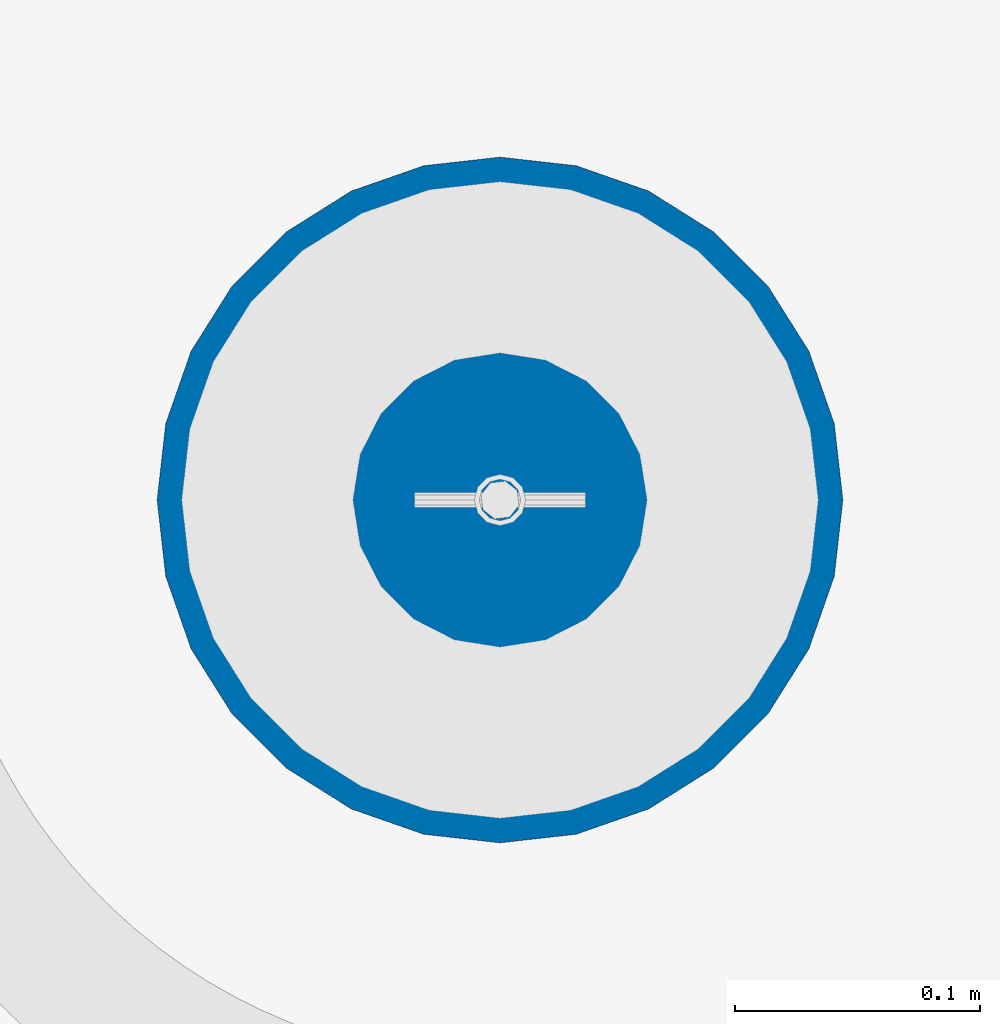
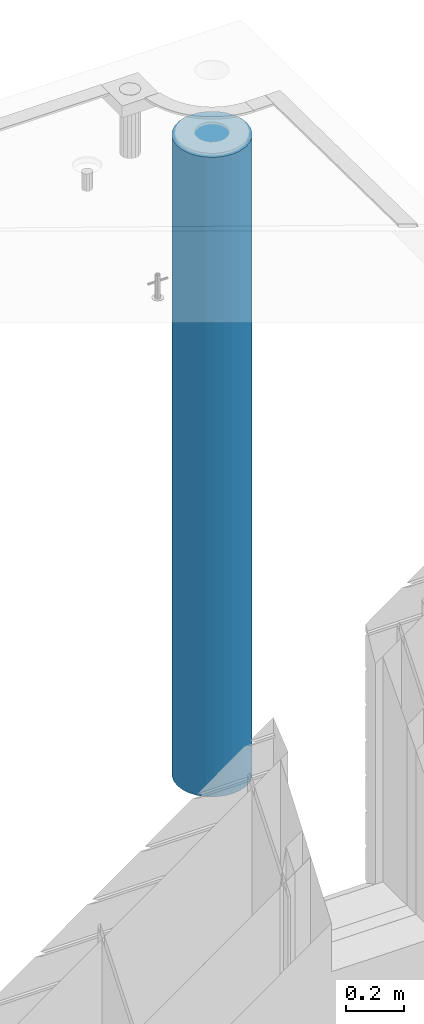
# One storey, part 7 of 341: 1 column, 1 element without a shape of its own.
"""IFC2X3 building model written with IfcOpenShell, lengths in millimetres."""

from ifc_helpers import new_model, si_unit, frame, origin_with_axes, place, context, subcontext, project, spatial, faceted_brep, material, type_object, element, aggregate, save


model = new_model("IFC2X3")

# Units and contexts
model_context = context("Model", 3, precision=1e-05, world=origin_with_axes())
body_context = subcontext(model_context, "Body", "Model", "MODEL_VIEW")
ifc_project = project(units=[si_unit("LENGTHUNIT", "METRE", prefix="MILLI"), si_unit("AREAUNIT", "SQUARE_METRE"), si_unit("VOLUMEUNIT", "CUBIC_METRE"), si_unit("MASSUNIT", "GRAM", prefix="KILO"), si_unit("TIMEUNIT", "SECOND"), si_unit("PLANEANGLEUNIT", "RADIAN"), si_unit("SOLIDANGLEUNIT", "STERADIAN"), si_unit("THERMODYNAMICTEMPERATUREUNIT", "DEGREE_CELSIUS"), si_unit("LUMINOUSINTENSITYUNIT", "LUMEN")], contexts=[model_context])

# Site, building, storey
site_placement = place(None, origin_with_axes())
site = spatial("IfcSite", under=ifc_project, at=site_placement, CompositionType="ELEMENT")
building_placement = place(site_placement, origin_with_axes())
building = spatial("IfcBuilding", under=site, at=building_placement, CompositionType="ELEMENT")
storey_placement = place(building_placement, origin_with_axes())
storey = spatial("IfcBuildingStorey", under=building, at=storey_placement, Name="5", CompositionType="ELEMENT", Elevation=0.0)

# Assembly, column
assembly_placement = place(storey_placement, origin_with_axes())
assembly = element("IfcElementAssembly", 1, at=assembly_placement, inside=storey, AssemblyPlace="NOTDEFINED", PredefinedType="REINFORCEMENT_UNIT")
ifc_material = material(Name="CONCRETE/C30/37")
column_type = type_object("IfcColumnType", Name="D280", PredefinedType="NOTDEFINED")
column_placement = place(assembly_placement, frame((35009.9987952044, 22669.984888838, 93725.0), z_axis=(-1.0, 3.00000001838171e-08, 0.0), x_axis=(0.0, 0.0, 1.0)))
column = element("IfcColumn", 2, at=column_placement, type_object=column_type, material=ifc_material, ObjectType="D280", context=body_context, shape_type="Brep", body=[
    faceted_brep([(0.0, -140.0, 0.0), (0.0, -136.489907705454, -31.1529307538876), (2710.0, -136.489907705454, -31.1529307538876), (2710.0, -140.0, 0.0), (0.0, -126.135641506338, -60.7437234764584), (2710.0, -126.135641506338, -60.7437234764584), (0.0, -109.456407545524, -87.2885722602223), (2710.0, -109.456407545524, -87.2885722602223), (0.0, -87.2885722602223, -109.456407545527), (2710.0, -87.2885722602223, -109.456407545527), (0.0, -60.7437234764584, -126.135641506342), (2710.0, -60.7437234764584, -126.135641506342), (0.0, -31.152930753884, -136.489907705458), (2710.0, -31.152930753884, -136.489907705458), (0.0, 0.0, -140.0), (2710.0, 0.0, -140.0), (0.0, 31.152930753884, -136.489907705458), (2710.0, 31.152930753884, -136.489907705458), (0.0, 60.7437234764584, -126.135641506342), (2710.0, 60.7437234764584, -126.135641506342), (0.0, 87.2885722602223, -109.456407545527), (2710.0, 87.2885722602223, -109.456407545527), (0.0, 109.456407545524, -87.2885722602223), (2710.0, 109.456407545524, -87.2885722602223), (0.0, 126.135641506338, -60.7437234764584), (2710.0, 126.135641506338, -60.7437234764584), (0.0, 136.489907705454, -31.1529307538876), (2710.0, 136.489907705454, -31.1529307538876), (0.0, 140.0, 0.0), (2710.0, 140.0, 0.0), (0.0, 136.489907705454, 31.1529307538876), (2710.0, 136.489907705454, 31.1529307538876), (0.0, 126.135641506338, 60.7437234764584), (2710.0, 126.135641506338, 60.7437234764584), (0.0, 109.456407545524, 87.2885722602223), (2710.0, 109.456407545524, 87.2885722602223), (0.0, 87.2885722602223, 109.456407545527), (2710.0, 87.2885722602223, 109.456407545527), (0.0, 60.7437234764584, 126.135641506342), (2710.0, 60.7437234764584, 126.135641506342), (0.0, 31.152930753884, 136.489907705458), (2710.0, 31.152930753884, 136.489907705458), (0.0, 0.0, 140.0), (2710.0, 0.0, 140.0), (0.0, -31.152930753884, 136.489907705458), (2710.0, -31.152930753884, 136.489907705458), (0.0, -60.7437234764584, 126.135641506342), (2710.0, -60.7437234764584, 126.135641506342), (0.0, -87.2885722602223, 109.456407545527), (2710.0, -87.2885722602223, 109.456407545527), (0.0, -109.456407545524, 87.2885722602223), (2710.0, -109.456407545524, 87.2885722602223), (0.0, -126.135641506338, 60.7437234764584), (2710.0, -126.135641506338, 60.7437234764584), (0.0, -136.489907705454, 31.1529307538876), (2710.0, -136.489907705454, 31.1529307538876)], [[[0, 1, 2, 3]], [[1, 4, 5, 2]], [[4, 6, 7, 5]], [[6, 8, 9, 7]], [[8, 10, 11, 9]], [[10, 12, 13, 11]], [[12, 14, 15, 13]], [[14, 16, 17, 15]], [[16, 18, 19, 17]], [[18, 20, 21, 19]], [[20, 22, 23, 21]], [[22, 24, 25, 23]], [[24, 26, 27, 25]], [[26, 28, 29, 27]], [[28, 30, 31, 29]], [[30, 32, 33, 31]], [[32, 34, 35, 33]], [[34, 36, 37, 35]], [[36, 38, 39, 37]], [[38, 40, 41, 39]], [[40, 42, 43, 41]], [[42, 44, 45, 43]], [[44, 46, 47, 45]], [[46, 48, 49, 47]], [[48, 50, 51, 49]], [[50, 52, 53, 51]], [[52, 54, 55, 53]], [[54, 0, 3, 55]], [[5, 7, 9, 11, 13, 15, 17, 19, 21, 23, 25, 27, 29, 31, 33, 35, 37, 39, 41, 43, 45, 47, 49, 51, 53, 55, 3, 2]], [[54, 52, 50, 48, 46, 44, 42, 40, 38, 36, 34, 32, 30, 28, 26, 24, 22, 20, 18, 16, 14, 12, 10, 8, 6, 4, 1, 0]]]),
])
aggregate(assembly, [column])

save(model, "model.ifc")
